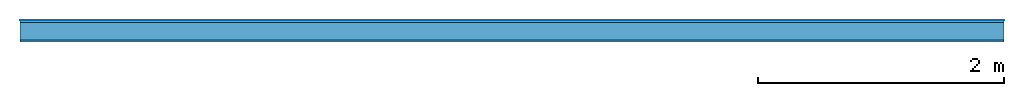
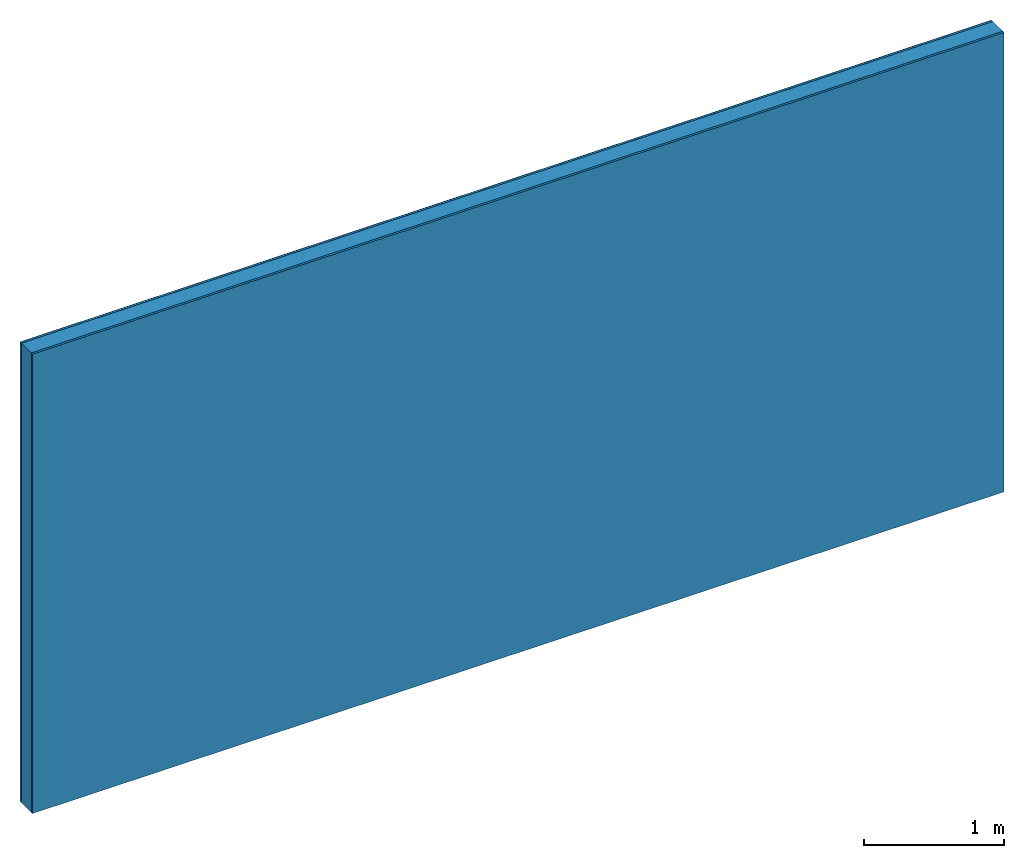
# One storey: 3 plates, 1 member, 1 element without a shape of its own.
"""IFC4 building model written with IfcOpenShell, lengths in metres."""

from ifc_helpers import new_model, si_unit, derived_unit, direction, frame, frame_2d, origin, origin_with_axes, place, context, project, spatial, rectangle, extrude, material, layer, layer_set, type_object, element, aggregate, save


model = new_model("IFC4")

# Units and contexts
plan_context = context("Plan", 3, precision=1e-05, world=origin(), true_north=direction((0.0, 1.0)))
model_context = context("Model", 3, precision=1e-05, world=origin(), true_north=direction((0.0, 1.0)))
ifc_project = project(units=[si_unit("LENGTHUNIT", "METRE"), derived_unit("SOUNDPRESSUREUNIT", [(si_unit("PRESSUREUNIT", "PASCAL", prefix="MICRO"), 0)]), si_unit("ENERGYUNIT", "JOULE", prefix="MEGA"), si_unit("MASSUNIT", "GRAM", prefix="KILO"), derived_unit("THERMALTRANSMITTANCEUNIT", [(si_unit("POWERUNIT", "WATT"), 1), (si_unit("AREAUNIT", "SQUARE_METRE"), -1), (si_unit("THERMODYNAMICTEMPERATUREUNIT", "KELVIN"), -1)]), derived_unit("AREADENSITYUNIT", [(si_unit("MASSUNIT", "GRAM", prefix="KILO"), 1), (si_unit("AREAUNIT", "SQUARE_METRE"), -1)]), derived_unit("USERDEFINED", [(si_unit("ENERGYUNIT", "JOULE", prefix="MEGA"), 1), (si_unit("AREAUNIT", "SQUARE_METRE"), -1)])], contexts=[plan_context, model_context])

# Site, building, storey
site = spatial("IfcSite", under=ifc_project)
building_placement = place(None, origin())
building = spatial("IfcBuilding", under=site, at=building_placement)
storey_placement = place(building_placement, origin())
storey = spatial("IfcBuildingStorey", under=building, at=storey_placement)

# Wall, member, plates
ifc_material_1 = material(Category="04.001")
ifc_layer_1 = layer(ifc_material_1, 0.003, Name="Surface")
ifc_material_2 = material(Category="03.007")
ifc_layer_2 = layer(ifc_material_2, 0.018, Name="1st layer")
ifc_material_3 = material(Name="of the art")
ifc_layer_3 = layer(ifc_material_3, 0.0, Name="Bond")
ifc_layer_4 = layer(None, 0.14, Name="Support")
ifc_layer_5 = layer(ifc_material_3, 0.0, Name="Bond")
ifc_layer_6 = layer(ifc_material_2, 0.018, Name="1st layer")
ifc_layer_set = layer_set([ifc_layer_1, ifc_layer_2, ifc_layer_3, ifc_layer_4, ifc_layer_5, ifc_layer_6])
wall_type = type_object("IfcWallType", Name="C0431", PredefinedType="NOTDEFINED", material=ifc_layer_set)
wall_placement = place(None, frame((0.0, 0.0, 0.0), z_axis=(0.0, -1.0, 0.0), x_axis=(1.0, 0.0, 0.0)))
wall = element("IfcWall", 1, at=wall_placement, inside=storey, type_object=wall_type, material=ifc_layer_set, Name="Wall #1")
ifc_material_4 = material(Name="Solid timber panel")
member_placement = place(wall_placement, origin())
member = element("IfcMember", 2, at=member_placement, material=ifc_material_4, Name="Support", context=plan_context, shape_type="SweptSolid", body=[
    extrude(rectangle(XDim=1.0, YDim=0.14, at=frame_2d((0.5, 0.07), x_axis=(1.0, 0.0))), frame((0.0, 4.0, 0.021), z_axis=(0.0, -1.0, 0.0), x_axis=(1.0, 0.0, 0.0)), (0.0, 0.0, 1.0), 4.0),
    extrude(rectangle(XDim=1.0, YDim=0.14, at=frame_2d((0.5, 0.07), x_axis=(1.0, 0.0))), frame((1.0, 4.0, 0.021), z_axis=(0.0, -1.0, 0.0), x_axis=(1.0, 0.0, 0.0)), (0.0, 0.0, 1.0), 4.0),
    extrude(rectangle(XDim=1.0, YDim=0.14, at=frame_2d((0.5, 0.07), x_axis=(1.0, 0.0))), frame((2.0, 4.0, 0.021), z_axis=(0.0, -1.0, 0.0), x_axis=(1.0, 0.0, 0.0)), (0.0, 0.0, 1.0), 4.0),
    extrude(rectangle(XDim=1.0, YDim=0.14, at=frame_2d((0.5, 0.07), x_axis=(1.0, 0.0))), frame((3.0, 4.0, 0.021), z_axis=(0.0, -1.0, 0.0), x_axis=(1.0, 0.0, 0.0)), (0.0, 0.0, 1.0), 4.0),
    extrude(rectangle(XDim=1.0, YDim=0.14, at=frame_2d((0.5, 0.07), x_axis=(1.0, 0.0))), frame((4.0, 4.0, 0.021), z_axis=(0.0, -1.0, 0.0), x_axis=(1.0, 0.0, 0.0)), (0.0, 0.0, 1.0), 4.0),
    extrude(rectangle(XDim=1.0, YDim=0.14, at=frame_2d((0.5, 0.07), x_axis=(1.0, 0.0))), frame((5.0, 4.0, 0.021), z_axis=(0.0, -1.0, 0.0), x_axis=(1.0, 0.0, 0.0)), (0.0, 0.0, 1.0), 4.0),
    extrude(rectangle(XDim=1.0, YDim=0.14, at=frame_2d((0.5, 0.07), x_axis=(1.0, 0.0))), frame((6.0, 4.0, 0.021), z_axis=(0.0, -1.0, 0.0), x_axis=(1.0, 0.0, 0.0)), (0.0, 0.0, 1.0), 4.0),
    extrude(rectangle(XDim=1.0, YDim=0.14, at=frame_2d((0.5, 0.07), x_axis=(1.0, 0.0))), frame((7.0, 4.0, 0.021), z_axis=(0.0, -1.0, 0.0), x_axis=(1.0, 0.0, 0.0)), (0.0, 0.0, 1.0), 4.0),
])
plate_1_placement = place(wall_placement, origin())
plate_1 = element("IfcPlate", 3, at=plate_1_placement, material=ifc_material_1, Name="Surface", context=plan_context, shape_type="SweptSolid", body=[
    extrude(rectangle(XDim=8.0, YDim=4.0, at=frame_2d((4.0, 2.0), x_axis=(1.0, 0.0))), origin_with_axes(), (0.0, 0.0, 1.0), 0.003),
])
plate_2_placement = place(wall_placement, origin())
plate_2 = element("IfcPlate", 4, at=plate_2_placement, material=ifc_material_2, Name="1st layer", context=plan_context, shape_type="SweptSolid", body=[
    extrude(rectangle(XDim=8.0, YDim=4.0, at=frame_2d((4.0, 2.0), x_axis=(1.0, 0.0))), frame((0.0, 0.0, 0.003), z_axis=(0.0, 0.0, 1.0), x_axis=(1.0, 0.0, 0.0)), (0.0, 0.0, 1.0), 0.018),
])
plate_3_placement = place(wall_placement, origin())
plate_3 = element("IfcPlate", 5, at=plate_3_placement, material=ifc_material_2, Name="1st layer", context=plan_context, shape_type="SweptSolid", body=[
    extrude(rectangle(XDim=8.0, YDim=4.0, at=frame_2d((4.0, 2.0), x_axis=(1.0, 0.0))), frame((0.0, 0.0, 0.161), z_axis=(0.0, 0.0, 1.0), x_axis=(1.0, 0.0, 0.0)), (0.0, 0.0, 1.0), 0.018),
])
aggregate(wall, [plate_1, plate_2, member, plate_3])

save(model, "model.ifc")
